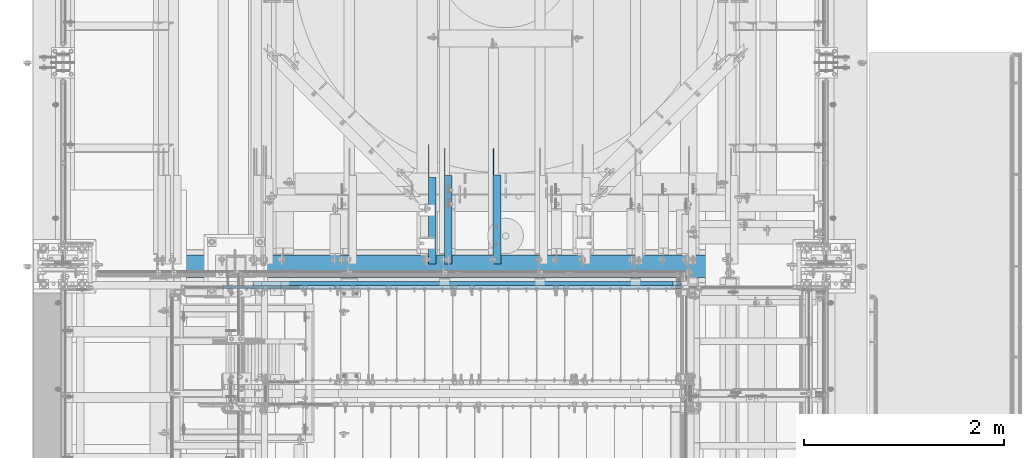
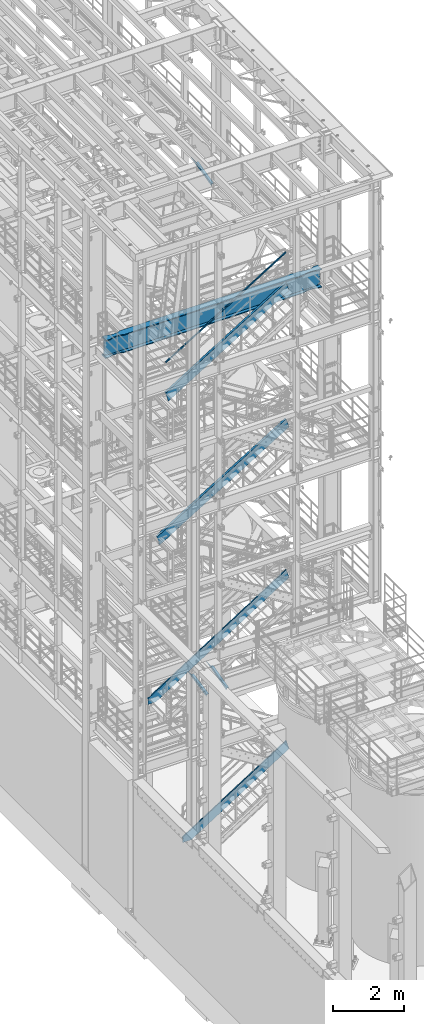
# One storey, part 979 of 1876: 5 members, 4 beams, 9 elements without a shape of their own.
"""IFC2X3 building model written with IfcOpenShell, lengths in millimetres."""

import ifcopenshell
import ifcopenshell.guid

model = None  # the IFC model being written
_history = None  # IfcOwnerHistory: only IFC2X3 demands one
_inside = {}  # id of a spatial element -> (the spatial element, [elements in it])
_under = {}  # id of a project, library or spatial element -> (it, [spatial elements below it])
_declared = {}  # id of a project -> (the project, [libraries it declares])
_typed = {}  # id of a type object -> (the type object, [elements of that type])
_made_of = {}  # id of a material, layer set ... -> (it, [elements and type objects made of it])


def new_model(schema):
    """Start an empty IFC model of exactly this schema.

    Asked for "IFC4X3", IfcOpenShell would pick the latest addendum, in which some entities
    have other attributes; the version numbers below select the first issue.
    IFC2X3 requires an IfcOwnerHistory on every rooted entity: one is made here for all.
    """
    global model, _history
    if schema == "IFC4X3":
        model = ifcopenshell.file(schema_version=(4, 3, 0, 0))
    else:
        model = ifcopenshell.file(schema=schema)
    _inside.clear()
    _under.clear()
    _declared.clear()
    _typed.clear()
    _made_of.clear()
    _history = None
    if model.schema == "IFC2X3":
        org = make("IfcOrganization", Name="unknown")
        user = make(
            "IfcPersonAndOrganization",
            ThePerson=make("IfcPerson", FamilyName="unknown"),
            TheOrganization=org,
        )
        app = make(
            "IfcApplication",
            ApplicationDeveloper=org,
            Version="unknown",
            ApplicationFullName="unknown",
            ApplicationIdentifier="unknown",
        )
        _history = make(
            "IfcOwnerHistory",
            OwningUser=user,
            OwningApplication=app,
            ChangeAction="ADDED",
            CreationDate=0,
        )
    return model


def make(cls, **values):
    """One entity of the class cls with the attributes given. An attribute that is None is left unset."""
    return model.create_entity(
        cls, **{name: value for name, value in values.items() if value is not None}
    )


def rooted(cls, **values):
    """An entity with a GlobalId (a new one), such as an element, a storey or a relation."""
    return make(cls, GlobalId=ifcopenshell.guid.new(), OwnerHistory=_history, **values)


def si_unit(unit_type, name, prefix=None):
    """IfcSIUnit, for example si_unit("LENGTHUNIT", "METRE", prefix="MILLI")."""
    return make("IfcSIUnit", UnitType=unit_type, Prefix=prefix, Name=name)


def assignment(units):
    """IfcUnitAssignment: the units of a project."""
    return None if units is None else make("IfcUnitAssignment", Units=units)


def point(xyz):
    """IfcCartesianPoint."""
    return None if xyz is None else make("IfcCartesianPoint", Coordinates=xyz)


def direction(xyz):
    """IfcDirection."""
    return None if xyz is None else make("IfcDirection", DirectionRatios=xyz)


def frame(location, z_axis=None, x_axis=None):
    """IfcAxis2Placement3D, a coordinate frame: its origin and axes. An axis left out is left unset."""
    return make(
        "IfcAxis2Placement3D",
        Location=point(location),
        Axis=direction(z_axis),
        RefDirection=direction(x_axis),
    )


def origin_with_axes():
    """The frame at (0, 0, 0) with the z axis (0, 0, 1) and the x axis (1, 0, 0) written out."""
    return frame((0.0, 0.0, 0.0), z_axis=(0.0, 0.0, 1.0), x_axis=(1.0, 0.0, 0.0))


def place(relative_to, where):
    """IfcLocalPlacement: puts the frame where relative to a parent placement (None: the world)."""
    return make(
        "IfcLocalPlacement", PlacementRelTo=relative_to, RelativePlacement=where
    )


def context(
    kind, dimensions, precision=None, world=None, true_north=None, identifier=None
):
    """IfcGeometricRepresentationContext, for example the 3D "Model" context."""
    return make(
        "IfcGeometricRepresentationContext",
        ContextIdentifier=identifier,
        ContextType=kind,
        CoordinateSpaceDimension=dimensions,
        Precision=precision,
        WorldCoordinateSystem=world,
        TrueNorth=true_north,
    )


def subcontext(parent, identifier, kind, view, scale=None):
    """IfcGeometricRepresentationSubContext, for example "Body" below "Model"."""
    return make(
        "IfcGeometricRepresentationSubContext",
        ContextIdentifier=identifier,
        ContextType=kind,
        ParentContext=parent,
        TargetScale=scale,
        TargetView=view,
    )


def project(units=None, contexts=None):
    """IfcProject with its units and contexts."""
    return rooted(
        "IfcProject",
        Name="project",
        RepresentationContexts=contexts,
        UnitsInContext=assignment(units),
    )


def spatial(cls, under=None, at=None, **own):
    """A site, building, storey or space (cls), placed at a placement, below another one or the project."""
    s = rooted(cls, ObjectPlacement=at, **own)
    if under is not None:
        _under.setdefault(under.id(), (under, []))[1].append(s)
    return s


def faces_of(points, faces, orient=None, outer=None):
    """IfcFace entities. A face is a list of loops; a loop is a list of indices into points, from 0.

    orient and outer hold one flag for each loop. By default every Orientation is true, the
    first loop of a face is its IfcFaceOuterBound and the others are IfcFaceBound.
    """
    made = []
    for i, loops in enumerate(faces):
        bounds = []
        for j, loop in enumerate(loops):
            is_outer = j == 0 if outer is None else outer[i][j]
            bounds.append(
                make(
                    "IfcFaceOuterBound" if is_outer else "IfcFaceBound",
                    Bound=make("IfcPolyLoop", Polygon=[points[k] for k in loop]),
                    Orientation=True if orient is None else orient[i][j],
                )
            )
        made.append(make("IfcFace", Bounds=bounds))
    return made


def faceted_brep(points, faces, orient=None, outer=None, voids=None):
    """IfcFacetedBrep: a solid bounded by flat faces; with voids (closed shells), ...WithVoids."""
    shared = [point(p) for p in points]
    hull = make("IfcClosedShell", CfsFaces=faces_of(shared, faces, orient, outer))
    if voids is None:
        return make("IfcFacetedBrep", Outer=hull)
    return make(
        "IfcFacetedBrepWithVoids",
        Outer=hull,
        Voids=[
            make(cls, CfsFaces=faces_of(shared, fs, o, b)) for cls, fs, o, b in voids
        ],
    )


def shape(context_of_items, identifier, shape_type, items):
    """IfcShapeRepresentation: the items that make up one representation, for example the "Body"."""
    return make(
        "IfcShapeRepresentation",
        ContextOfItems=context_of_items,
        RepresentationIdentifier=identifier,
        RepresentationType=shape_type,
        Items=items,
    )


def material(Name=None, Category=None):
    """IfcMaterial."""
    return make("IfcMaterial", Name=Name, Category=Category)


def made_of(thing, what):
    """Note that an element or type object is made of a material, layer set ...; save() writes the relation."""
    if what is not None:
        _made_of.setdefault(what.id(), (what, []))[1].append(thing)
    return thing


def type_object(cls, material=None, **own):
    """A type object (cls), such as IfcWallType, which elements share."""
    return made_of(rooted(cls, **own), material)


def element(
    cls,
    number,
    at=None,
    inside=None,
    cuts=None,
    type_object=None,
    material=None,
    context=None,
    identifier="Body",
    shape_type=None,
    held_by="IfcProductDefinitionShape",
    body=None,
    shapes=None,
    **own,
):
    """One element of the class cls, such as IfcWall. Its Tag is "e" and its number.

    at: its placement. inside: the storey or other place that contains it. cuts: it is an
    opening in that element (IfcRelVoidsElement). A single representation is given by context,
    identifier, shape_type and body (its items); several are given by shapes. held_by: the class
    of the entity that holds the representations. save() writes the other relations.
    """
    e = rooted(cls, Tag="e%d" % number, ObjectPlacement=at, **own)
    if body is not None:
        shapes = [shape(context, identifier, shape_type, body)]
    if shapes is not None:
        e.Representation = make(held_by, Representations=shapes)
    if inside is not None:
        _inside.setdefault(inside.id(), (inside, []))[1].append(e)
    if cuts is not None:
        rooted(
            "IfcRelVoidsElement", RelatingBuildingElement=cuts, RelatedOpeningElement=e
        )
    if type_object is not None:
        _typed.setdefault(type_object.id(), (type_object, []))[1].append(e)
    return made_of(e, material)


def aggregate(whole, parts):
    """IfcRelAggregates: a whole, such as a stair, and the parts it consists of."""
    return rooted("IfcRelAggregates", RelatingObject=whole, RelatedObjects=parts)


def save(model, path):
    """Write the relations noted so far, then the file.

    IfcRelAggregates (storeys below a building ...), IfcRelContainedInSpatialStructure (elements
    in a storey), IfcRelDefinesByType, IfcRelAssociatesMaterial and IfcRelDeclares: one each for
    every whole, place, type object, material and project.
    """
    for whole, parts in _under.values():
        aggregate(whole, parts)
    for where, things in _inside.values():
        rooted(
            "IfcRelContainedInSpatialStructure",
            RelatedElements=things,
            RelatingStructure=where,
        )
    for kind, things in _typed.values():
        rooted("IfcRelDefinesByType", RelatedObjects=things, RelatingType=kind)
    for what, things in _made_of.values():
        rooted("IfcRelAssociatesMaterial", RelatedObjects=things, RelatingMaterial=what)
    for by, libraries in _declared.values():
        rooted("IfcRelDeclares", RelatingContext=by, RelatedDefinitions=libraries)
    model.write(path)


model = new_model("IFC2X3")

# Units and contexts
model_context = context("Model", 3, precision=1e-05, world=origin_with_axes())
body_context = subcontext(model_context, "Body", "Model", "MODEL_VIEW")
ifc_project = project(units=[si_unit("LENGTHUNIT", "METRE", prefix="MILLI"), si_unit("AREAUNIT", "SQUARE_METRE"), si_unit("VOLUMEUNIT", "CUBIC_METRE"), si_unit("MASSUNIT", "GRAM", prefix="KILO"), si_unit("TIMEUNIT", "SECOND"), si_unit("PLANEANGLEUNIT", "RADIAN"), si_unit("SOLIDANGLEUNIT", "STERADIAN"), si_unit("THERMODYNAMICTEMPERATUREUNIT", "DEGREE_CELSIUS"), si_unit("LUMINOUSINTENSITYUNIT", "LUMEN")], contexts=[model_context])

# Site, building, storey
site_placement = place(None, origin_with_axes())
site = spatial("IfcSite", under=ifc_project, at=site_placement, CompositionType="ELEMENT")
building_placement = place(site_placement, origin_with_axes())
building = spatial("IfcBuilding", under=site, at=building_placement, Name="Undefined", CompositionType="ELEMENT")
storey_placement = place(building_placement, origin_with_axes())
storey = spatial("IfcBuildingStorey", under=building, at=storey_placement, Name="Undefined", CompositionType="ELEMENT", Elevation=0.0)

# Assembly, beam
assembly_1_placement = place(storey_placement, origin_with_axes())
assembly_1 = element("IfcElementAssembly", 1, at=assembly_1_placement, inside=storey, AssemblyPlace="NOTDEFINED", PredefinedType="RIGID_FRAME")
ifc_material_1 = material(Name="STEEL/A36")
beam_type_1 = type_object("IfcBeamType", Name="L3X3X3/8", PredefinedType="NOTDEFINED")
beam_1_placement = place(assembly_1_placement, frame((4333.87499990463, -4562.3143433578, 4558.96418871958), z_axis=(1.0, 0.0, 0.0), x_axis=(0.0, 0.967147277703795, 0.254216724922138)))
beam_1 = element("IfcBeam", 2, at=beam_1_placement, type_object=beam_type_1, material=ifc_material_1, ObjectType="L3X3X3/8", context=body_context, shape_type="Brep", body=[
    faceted_brep([(23.7928828385348, 38.099999999994, -38.1000000000004), (23.7928828385348, 38.099999999994, 38.1000000000004), (905.477403464634, 38.1000000000176, 38.1000000000004), (905.477403464634, 38.1000000000176, -38.1000000000004), (23.7809703256453, 28.5749999999953, 38.1000000000004), (941.714507152235, 28.5750000000207, 38.1000000000004), (23.7809703256453, 28.5749999999953, -28.5749999999998), (941.714507152235, 28.5750000000207, -28.5749999999998), (23.6975827354227, -38.0999999999913, -28.5749999999998), (1195.37423296544, -38.0999999999585, -28.5749999999998), (23.6975827354227, -38.0999999999913, -38.1000000000004), (1195.37423296544, -38.0999999999585, -38.1000000000004)], [[[0, 1, 2, 3]], [[1, 4, 5, 2]], [[4, 6, 7, 5]], [[6, 8, 9, 7]], [[8, 10, 11, 9]], [[10, 0, 3, 11]], [[5, 7, 9, 11, 3, 2]], [[10, 8, 6, 4, 1, 0]]]),
])
aggregate(assembly_1, [beam_1])

assembly_2_placement = place(storey_placement, origin_with_axes())
assembly_2 = element("IfcElementAssembly", 3, at=assembly_2_placement, inside=storey, AssemblyPlace="NOTDEFINED", PredefinedType="RIGID_FRAME")
beam_2_placement = place(assembly_2_placement, frame((3844.92500019074, -4562.78281844778, 21997.5317219592), z_axis=(1.0, 0.0, 0.0), x_axis=(0.0, 0.97029600569138, 0.241920774923019)))
beam_2 = element("IfcBeam", 4, at=beam_2_placement, type_object=beam_type_1, material=ifc_material_1, ObjectType="L3X3X3/8", context=body_context, shape_type="Brep", body=[
    faceted_brep([(20.4512332895073, 38.1000000000495, -38.0999999999999), (20.4512332895073, 38.1000000000495, 38.0999999999999), (892.440924395522, 38.0999999997366, 38.0999999999999), (892.440924395522, 38.0999999997366, -38.0999999999999), (20.4512332895037, 28.5750000000371, 38.0999999999999), (930.643800759319, 28.5749999997061, 38.0999999999999), (20.4512332895037, 28.5750000000371, -28.575), (930.643800759319, 28.5749999997061, -28.575), (20.4512332894728, -38.1000000000604, -28.575), (1198.0639353059, -38.1000000004824, -28.575), (20.4512332894728, -38.1000000000604, -38.0999999999999), (1198.0639353059, -38.1000000004824, -38.0999999999999)], [[[0, 1, 2, 3]], [[1, 4, 5, 2]], [[4, 6, 7, 5]], [[6, 8, 9, 7]], [[8, 10, 11, 9]], [[10, 0, 3, 11]], [[5, 7, 9, 11, 3, 2]], [[10, 8, 6, 4, 1, 0]]]),
])
aggregate(assembly_2, [beam_2])

assembly_3_placement = place(storey_placement, origin_with_axes())
assembly_3 = element("IfcElementAssembly", 5, at=assembly_3_placement, inside=storey, AssemblyPlace="NOTDEFINED", PredefinedType="RIGID_FRAME")
beam_3_placement = place(assembly_3_placement, frame((3685.38125, -4564.3470414959, 4572.77651984672), z_axis=(1.0, 0.0, 0.0), x_axis=(0.0, 0.979618903835332, 0.200865136966229)))
beam_3 = element("IfcBeam", 6, at=beam_3_placement, type_object=beam_type_1, material=ifc_material_1, ObjectType="L3X3X3/8", context=body_context, shape_type="Brep", body=[
    faceted_brep([(23.4976613090944, 38.0999999999913, -38.0999999999999), (23.4976613090944, 38.0999999999913, 38.0999999999999), (853.557777655543, 38.0999999998658, 38.0999999999999), (853.557777655543, 38.0999999998658, -38.0999999999999), (23.4976613090939, 28.5749999999935, 38.0999999999999), (900.01118515057, 28.5749999998607, 38.0999999999999), (23.4976613090939, 28.5749999999935, -28.5749999999998), (900.01118515057, 28.5749999998607, -28.5749999999998), (23.4976613090939, -38.0999999999976, -28.5749999999998), (1225.18503761576, -38.1000000001786, -28.5749999999998), (23.4976613090939, -38.0999999999976, -38.0999999999999), (1225.18503761576, -38.1000000001786, -38.0999999999999)], [[[0, 1, 2, 3]], [[1, 4, 5, 2]], [[4, 6, 7, 5]], [[6, 8, 9, 7]], [[8, 10, 11, 9]], [[10, 0, 3, 11]], [[5, 7, 9, 11, 3, 2]], [[10, 8, 6, 4, 1, 0]]]),
])
aggregate(assembly_3, [beam_3])

# Assembly, member
assembly_4_placement = place(storey_placement, origin_with_axes())
assembly_4 = element("IfcElementAssembly", 7, at=assembly_4_placement, inside=storey, Name="RAIL", AssemblyPlace="NOTDEFINED", PredefinedType="RIGID_FRAME")
ifc_material_2 = material()
member_type_1 = type_object("IfcMemberType", Name="HSS1-1/2X1-1/2X1/8", PredefinedType="NOTDEFINED")
member_1_placement = place(assembly_4_placement, frame((6080.62411478707, -4781.55000114554, 19050.0), z_axis=(0.526627379729771, 0.0, -0.850096231563789), x_axis=(-0.850096231563789, 0.0, -0.526627379729771)))
member_1 = element("IfcMember", 8, at=member_1_placement, type_object=member_type_1, material=ifc_material_2, Name="RAIL", ObjectType="HSS1-1/2X1-1/2X1/8", context=body_context, shape_type="Brep", body=[
    faceted_brep([(-4.5187969689996, 15.8749992829999, -15.8749992829871), (-4.5187969689996, -15.8749992829999, -15.8749992829871), (4579.03162456834, -15.8749992829999, -15.8749992763478), (4579.03162456834, 15.8749992829999, -15.8749992763478), (4.51879699284473, -15.8749992829999, 15.8749992829871), (4588.06921853025, -15.8749992829999, 15.8749992896428), (4.51879699284473, 15.8749992829999, 15.8749992829871), (4588.06921853025, 15.8749992829999, 15.8749992896428), (-5.42255639234099, 19.0499992349996, -19.0499992349833), (5.42255641618613, 19.0499992349996, 19.0499992349851), (4588.97297795359, 19.0499992349996, 19.0499992416389), (4578.12786514499, 19.0499992349996, -19.0499992283476), (5.42255641618613, -19.0499992349996, 19.0499992349851), (4588.97297795359, -19.0499992349996, 19.0499992416389), (-5.42255639234099, -19.0499992349996, -19.0499992349833), (4578.12786514499, -19.0499992349996, -19.0499992283476)], [[[0, 1, 2, 3]], [[1, 4, 5, 2]], [[4, 6, 7, 5]], [[6, 0, 3, 7]], [[8, 9, 10, 11]], [[9, 12, 13, 10]], [[12, 14, 15, 13]], [[14, 8, 11, 15]], [[13, 15, 11, 10], [5, 7, 3, 2]], [[14, 12, 9, 8], [6, 4, 1, 0]]]),
])
aggregate(assembly_4, [member_1])

assembly_5_placement = place(storey_placement, origin_with_axes())
assembly_5 = element("IfcElementAssembly", 9, at=assembly_5_placement, inside=storey, Name="STRINGER", AssemblyPlace="NOTDEFINED", PredefinedType="RIGID_FRAME")
member_type_2 = type_object("IfcMemberType", Name="C12X20.7", PredefinedType="NOTDEFINED")
member_2_placement = place(assembly_5_placement, frame((6169.03104247719, -4762.50000114494, 17888.572489046), z_axis=(-0.526650190166568, 0.0, 0.850082100268861), x_axis=(-0.850082100268861, 0.0, -0.526650190166567)))
member_2 = element("IfcMember", 10, at=member_2_placement, type_object=member_type_2, material=ifc_material_1, Name="STRINGER", ObjectType="C12X20.7", context=body_context, shape_type="Brep", body=[
    faceted_brep([(86.7653265610461, 38.1000000000004, -152.399999999901), (0.0, 38.1000000000004, 152.4), (4601.43790875364, 38.1000000000004, 152.399999995085), (4688.20323538842, 38.1000000000004, -152.400000004627), (0.0, -38.1000000000004, 152.4), (4601.43790875364, -38.1000000000004, 152.399999995085), (1.80833394220826, -38.1000000000004, 146.04745999982), (4603.24624276958, -38.1000000000004, 146.04745999509), (5.04567481172126, 30.1625000000004, 134.674927499829), (4606.4835836391, 30.1625000000004, 134.674927495102), (81.7196516755866, 30.1625000000004, -134.674927499917), (4683.15756050296, 30.1625000000004, -134.674927504644), (84.9569925450996, -38.1000000000004, -146.047459999907), (4686.39490137247, -38.1000000000004, -146.047460004633), (86.7653265610461, -38.1000000000004, -152.399999999901), (4688.20323538842, -38.1000000000004, -152.400000004627)], [[[0, 1, 2, 3]], [[1, 4, 5, 2]], [[4, 6, 7, 5]], [[6, 8, 9, 7]], [[8, 10, 11, 9]], [[10, 12, 13, 11]], [[12, 14, 15, 13]], [[14, 0, 3, 15]], [[5, 7, 9, 11, 13, 15, 3, 2]], [[14, 12, 10, 8, 6, 4, 1, 0]]]),
])
aggregate(assembly_5, [member_2])

assembly_6_placement = place(storey_placement, origin_with_axes())
assembly_6 = element("IfcElementAssembly", 11, at=assembly_6_placement, inside=storey, Name="STRINGER", AssemblyPlace="NOTDEFINED", PredefinedType="RIGID_FRAME")
member_3_placement = place(assembly_6_placement, frame((6168.66354763905, -4762.50000114942, 13214.7187687466), z_axis=(-0.523953411146183, 0.0, 0.851746924237639), x_axis=(-0.851746924237639, 0.0, -0.523953411146184)))
member_3 = element("IfcMember", 12, at=member_3_placement, type_object=member_type_2, material=ifc_material_1, Name="STRINGER", ObjectType="C12X20.7", context=body_context, shape_type="Brep", body=[
    faceted_brep([(86.2434264438216, 38.1000000000004, -152.400000000001), (0.0, 38.1000000000004, 152.4), (4920.47564755946, 38.1000000000004, 152.400000001153), (5006.71907404049, 38.1000000000004, -152.399999998875), (0.0, -38.1000000000004, 152.4), (4920.47564755946, -38.1000000000004, 152.400000001153), (1.79745670970442, -38.1000000000004, 146.047460000024), (4922.27310430637, -38.1000000000004, 146.047460001151), (5.01532472337567, 30.1625000000004, 134.674927500021), (4925.49097232005, 30.1625000000004, 134.674927501152), (81.2281016832421, 30.1625000000004, -134.674927499999), (5001.70374927992, 30.1625000000004, -134.674927498872), (84.4459696969134, -38.1000000000004, -146.047460000002), (5004.92161729358, -38.1000000000004, -146.047459998875), (86.2434264438216, -38.1000000000004, -152.400000000001), (5006.71907404049, -38.1000000000004, -152.399999998875)], [[[0, 1, 2, 3]], [[1, 4, 5, 2]], [[4, 6, 7, 5]], [[6, 8, 9, 7]], [[8, 10, 11, 9]], [[10, 12, 13, 11]], [[12, 14, 15, 13]], [[14, 0, 3, 15]], [[5, 7, 9, 11, 13, 15, 3, 2]], [[14, 12, 10, 8, 6, 4, 1, 0]]]),
])
aggregate(assembly_6, [member_3])

assembly_7_placement = place(storey_placement, origin_with_axes())
assembly_7 = element("IfcElementAssembly", 13, at=assembly_7_placement, inside=storey, Name="STRINGER", AssemblyPlace="NOTDEFINED", PredefinedType="RIGID_FRAME")
member_type_3 = type_object("IfcMemberType", Name="MC12X10.6", PredefinedType="NOTDEFINED")
member_4_placement = place(assembly_7_placement, frame((6170.42332168081, -4781.55000113033, 8059.75098794068), z_axis=(-0.536875491934336, 0.0, 0.843661487896813), x_axis=(-0.843661487896813, 0.0, -0.536875491934336)))
member_4 = element("IfcMember", 14, at=member_4_placement, type_object=member_type_3, material=ifc_material_1, Name="STRINGER", ObjectType="MC12X10.6", context=body_context, shape_type="Brep", body=[
    faceted_brep([(88.7579695903842, -19.0500000000002, -152.399999999925), (86.5569568567735, -19.0500000000002, -144.841594999928), (86.3637695885682, 14.2875000000004, -144.178178749929), (2.39419999348684, 14.2875000000004, 144.178178749939), (2.20101272528336, -19.0500000000002, 144.841594999938), (-1.68647966347635e-06, -19.0500000000002, 152.400000000001), (-1.68647966347635e-06, 19.0500000000002, 152.400000000001), (88.7579695903842, 19.0500000000002, -152.399999999925), (5204.2363930058, 19.0500000000002, -152.39999999936), (5204.2363930058, -19.0500000000002, -152.39999999936), (5216.11388656315, -19.0500000000002, -144.841594999362), (5217.15639781191, 14.2875000000004, -144.178178749362), (5424.79425146145, 14.2875000000004, -12.0449989975828), (5325.37950186754, 14.2875000000004, 144.178178750526), (5324.95732788977, -19.0500000000002, 144.841595000525), (5320.14743379316, -19.0500000000002, 152.400000000522), (5320.14743379316, 19.0500000000002, 152.400000000522), (5424.79425146145, 19.0500000000002, -12.0449989975828)], [[[0, 1, 2, 3, 4, 5, 6, 7]], [[0, 7, 8, 9]], [[1, 0, 9, 10]], [[2, 1, 10, 11]], [[3, 2, 11, 12, 13]], [[4, 3, 13, 14]], [[5, 4, 14, 15]], [[6, 5, 15, 16]], [[8, 7, 6, 16, 17]], [[11, 10, 9, 8, 17, 12]], [[16, 15, 14, 13, 12, 17]]]),
])
aggregate(assembly_7, [member_4])

assembly_8_placement = place(storey_placement, origin_with_axes())
assembly_8 = element("IfcElementAssembly", 15, at=assembly_8_placement, inside=storey, Name="STRINGER", AssemblyPlace="NOTDEFINED", PredefinedType="RIGID_FRAME")
member_5_placement = place(assembly_8_placement, frame((6170.26301538892, -4781.55000120553, 2200.99553374349), z_axis=(-0.53569741975471, 0.0, 0.844410015613355), x_axis=(-0.844410015613354, 0.0, -0.53569741975471)))
member_5 = element("IfcMember", 16, at=member_5_placement, type_object=member_type_3, material=ifc_material_1, Name="STRINGER", ObjectType="MC12X10.6", context=body_context, shape_type="Brep", body=[
    faceted_brep([(88.527264823621, -19.0500000000002, -152.4), (86.3319730877715, -19.0500000000002, -144.841595), (86.1392879629268, 14.2875000000004, -144.17817875), (2.38797685967643, 14.2875000000004, 144.17817875), (2.19529173483147, -19.0500000000002, 144.841595), (-1.68647966347635e-06, -19.0500000000002, 152.400000000001), (-1.68647966347635e-06, 19.0500000000002, 152.400000000001), (88.527264823621, 19.0500000000002, -152.4), (3844.87479961239, 19.0500000000002, -152.400000001044), (3844.87479961239, -19.0500000000002, -152.400000001044), (3856.78897475809, -19.0500000000002, -144.841595001047), (3857.83470562287, 14.2875000000004, -144.178178751047), (4087.60257997168, 14.2875000000004, 1.5875691147512), (3997.14247143452, 14.2875000000004, 144.178178748953), (3996.72159725399, -19.0500000000002, 144.841594998953), (3991.92651195054, -19.0500000000002, 152.399999998955), (3991.92651195054, 19.0500000000002, 152.399999998955), (4087.60257997168, 19.0500000000002, 1.5875691147512)], [[[0, 1, 2, 3, 4, 5, 6, 7]], [[0, 7, 8, 9]], [[1, 0, 9, 10]], [[2, 1, 10, 11]], [[3, 2, 11, 12, 13]], [[4, 3, 13, 14]], [[5, 4, 14, 15]], [[6, 5, 15, 16]], [[8, 7, 6, 16, 17]], [[11, 10, 9, 8, 17, 12]], [[16, 15, 14, 13, 12, 17]]]),
])
aggregate(assembly_8, [member_5])

# Assembly, beam
assembly_9_placement = place(storey_placement, origin_with_axes())
assembly_9 = element("IfcElementAssembly", 17, at=assembly_9_placement, inside=storey, Name="BEAM", AssemblyPlace="NOTDEFINED", PredefinedType="RIGID_FRAME")
ifc_material_3 = material(Name="STEEL/A992")
beam_type_2 = type_object("IfcBeamType", Name="W24X103", PredefinedType="NOTDEFINED")
beam_4_placement = place(assembly_9_placement, frame((0.0, -4572.0, 17672.05), z_axis=(0.0, 0.0, 1.0), x_axis=(1.0, 0.0, 0.0)))
beam_4 = element("IfcBeam", 18, at=beam_4_placement, type_object=beam_type_2, material=ifc_material_3, Name="BEAM", ObjectType="W24X103", context=body_context, shape_type="Brep", body=[
    faceted_brep([(301.625, 7.14375000000018, -250.825000000001), (309.5625, -7.14375000000018, -250.825000000001), (309.5625, -7.14375000000018, 250.825000000001), (301.625, 7.14375000000018, 250.825000000001), (7318.375, 7.14375000000018, 250.825000000001), (7310.4375, -7.14375000000018, 250.825000000001), (7310.4375, -7.14375000000018, -250.825000000001), (7318.375, 7.14375000000018, -250.825000000001), (7162.79999999982, 114.299999516767, -285.75), (7162.79999999982, 114.3, -311.150000000001), (7113.70085269938, 88.9000029223316, -311.150000000001), (7113.70085269938, 88.9000029223316, -285.75), (7031.26184334843, 69.8863995920019, -311.150000000001), (7031.26184334843, 69.8863995920019, -285.75), (6946.89999522536, 63.5000112833413, -311.150000000001), (6946.89999522536, 63.5000112833413, -285.75), (6862.53814723751, 69.8864013782631, -311.150000000001), (6862.53814723751, 69.8864013782631, -285.75), (6780.09913828916, 88.9000064541397, -311.150000000001), (6780.09913828916, 88.9000064541397, -285.75), (6730.99999123786, 114.3, -311.150000000001), (6730.99999123786, 114.3, -285.75), (889.000008761879, 114.3, -311.150000000001), (889.000008761879, 114.299990374482, -285.75), (839.9008617106, 88.8999896424721, -311.150000000001), (839.9008617106, 88.8999896424721, -285.75), (757.461852762268, 69.8863845665956, -311.150000000001), (757.461852762268, 69.8863845665956, -285.75), (673.100004774441, 63.4999944716737, -311.150000000001), (673.100004774441, 63.4999944716737, -285.75), (588.738156651386, 69.8863827803343, -311.150000000001), (588.738156651386, 69.8863827803343, -285.75), (506.299147300449, 88.899986110664, -311.150000000001), (506.299147300449, 88.899986110664, -285.75), (457.200000000009, 114.3, -311.150000000001), (457.200000000009, 114.3, -285.75), (301.625, 114.3, -311.150000000001), (316.28959905754, 114.3, -285.75), (7162.79999999982, -114.299985144468, -285.75), (7113.70085269938, -88.8999885500325, -285.75), (7113.70085269938, -88.8999885500325, -311.150000000001), (7162.79999999982, -114.3, -311.150000000001), (7031.26184334843, -69.8863852197028, -285.75), (7031.26184334843, -69.8863852197028, -311.150000000001), (6946.89999522536, -63.4999969110422, -285.75), (6946.89999522536, -63.4999969110422, -311.150000000001), (6862.53814723751, -69.886387005964, -285.75), (6862.53814723751, -69.886387005964, -311.150000000001), (6780.09913828916, -88.8999920818405, -285.75), (6780.09913828916, -88.8999920818405, -311.150000000001), (6730.99999123786, -114.3, -285.75), (6730.99999123786, -114.3, -311.150000000001), (889.000008761879, -114.300009625518, -285.75), (889.000008761879, -114.3, -311.150000000001), (839.9008617106, -88.9000088935081, -285.75), (839.9008617106, -88.9000088935081, -311.150000000001), (757.461852762268, -69.8864038176316, -285.75), (757.461852762268, -69.8864038176316, -311.150000000001), (673.100004774441, -63.5000137227098, -285.75), (673.100004774441, -63.5000137227098, -311.150000000001), (588.738156651386, -69.8864020313704, -285.75), (588.738156651386, -69.8864020313704, -311.150000000001), (506.299147300449, -88.9000053617001, -285.75), (506.299147300449, -88.9000053617001, -311.150000000001), (457.200000000009, -114.3, -285.75), (457.200000000009, -114.3, -311.150000000001), (316.28959905754, -114.3, -285.75), (301.625, -114.3, -311.150000000001), (316.518799385621, -7.14375000000018, -285.35299987793), (316.518799385621, 7.14375000000018, -285.35299987793), (316.28959905754, 7.14375000000018, -285.75), (316.28959905754, -7.14375000000018, -285.75), (350.084996826172, -7.14375000000018, -285.35299987793), (350.084996826172, 7.14375000000018, -285.35299987793), (385.557251149282, -7.14375000000018, -269.000062630286), (385.557251149282, 7.14375000000018, -269.000062630286), (389.447459055476, -7.14375000000018, -265.703842989446), (389.447459055476, 7.14375000000018, -265.703842989446), (391.080124802588, -7.14375000000018, -260.873399528195), (391.080124802588, 7.14375000000018, -260.873399528195), (389.98738362386, -7.14375000000018, -255.89296800167), (389.98738362386, 7.14375000000018, -255.89296800167), (386.482376832887, -7.14375000000018, -252.189765486371), (386.482376832887, 7.14375000000018, -252.189765486371), (381.56951650093, -7.14375000000018, -250.825000000001), (381.56951650093, 7.14375000000018, -250.825000000001), (380.734514535493, -7.14375000000018, 250.825000000001), (380.734514535493, 7.14375000000018, 250.825000000001), (385.647374804242, -7.14375000000018, 252.189765448315), (385.647374804242, 7.14375000000018, 252.189765448315), (389.152381589376, -7.14375000000018, 255.892967871263), (389.152381589376, 7.14375000000018, 255.892967871263), (390.245122849314, -7.14375000000018, 260.873399307191), (390.245122849314, 7.14375000000018, 260.873399307191), (388.612457255921, -7.14375000000018, 265.703842745359), (388.612457255921, 7.14375000000018, 265.703842745359), (384.722249518856, -7.14375000000018, 269.000062475843), (384.722249518856, 7.14375000000018, 269.000062475843), (349.249998474121, -7.14375000000018, 285.35299987793), (349.249998474121, 7.14375000000018, 285.35299987793), (301.625, -7.14375000000018, 285.35299987793), (301.625, 7.14375000000018, 285.35299987793), (457.200000000009, 114.3, 311.150000000001), (457.200000000009, 114.3, 285.75), (301.625, 114.3, 285.75), (316.289586308271, 114.3, 311.150000000001), (506.299147300449, 88.899986110664, 311.150000000001), (506.299147300449, 88.899986110664, 285.75), (588.738156651386, 69.8863827803343, 311.150000000001), (588.738156651386, 69.8863827803343, 285.75), (673.100004774441, 63.4999944716737, 311.150000000001), (673.100004774441, 63.4999944716737, 285.75), (757.461852762268, 69.8863845665956, 311.150000000001), (757.461852762268, 69.8863845665956, 285.75), (839.9008617106, 88.8999896424721, 311.150000000001), (839.9008617106, 88.8999896424721, 285.75), (889.000008761879, 114.299990374482, 311.150000000001), (889.000008761879, 114.3, 285.75), (6730.99999123786, 114.3, 311.150000000001), (6730.99999123786, 114.3, 285.75), (6780.09913828916, 88.9000064541397, 311.150000000001), (6780.09913828916, 88.9000064541397, 285.75), (6862.53814723751, 69.8864013782631, 311.150000000001), (6862.53814723751, 69.8864013782631, 285.75), (6946.89999522536, 63.5000112833413, 311.150000000001), (6946.89999522536, 63.5000112833413, 285.75), (7031.26184334843, 69.8863995920019, 311.150000000001), (7031.26184334843, 69.8863995920019, 285.75), (7113.70085269938, 88.9000029223316, 311.150000000001), (7113.70085269938, 88.9000029223316, 285.75), (7162.79999999982, 114.299999516767, 311.150000000001), (7162.79999999982, 114.3, 285.75), (7303.71041369173, 114.29999995445, 311.150000000001), (7318.375, 114.3, 285.75), (301.625, 7.14375000000018, 285.75), (7318.375, 7.14375000000018, 285.75), (7318.375, -7.14375000000018, 285.35299987793), (7318.375, 7.14375000000018, 285.35299987793), (7318.375, -7.14375000000018, 285.75), (7270.75000152588, -7.14375000000018, 285.35299987793), (7270.75000152588, 7.14375000000018, 285.35299987793), (7235.27775048114, -7.14375000000018, 269.000062475843), (7235.27775048114, 7.14375000000018, 269.000062475843), (7231.38754274408, -7.14375000000018, 265.703842745359), (7231.38754274408, 7.14375000000018, 265.703842745359), (7229.75487715069, -7.14375000000018, 260.873399307191), (7229.75487715069, 7.14375000000018, 260.873399307191), (7230.84761841062, -7.14375000000018, 255.892967871263), (7230.84761841062, 7.14375000000018, 255.892967871263), (7234.35262519576, -7.14375000000018, 252.189765448315), (7234.35262519576, 7.14375000000018, 252.189765448315), (7239.26548546451, -7.14375000000018, 250.825000000001), (7239.26548546451, 7.14375000000018, 250.825000000001), (7238.43048349907, -7.14375000000018, -250.825000000001), (7238.43048349907, 7.14375000000018, -250.825000000001), (7233.51762316711, -7.14375000000018, -252.189765486371), (7233.51762316711, 7.14375000000018, -252.189765486371), (7230.01261637614, -7.14375000000018, -255.89296800167), (7230.01261637614, 7.14375000000018, -255.89296800167), (7228.91987519741, -7.14375000000018, -260.873399528195), (7228.91987519741, 7.14375000000018, -260.873399528195), (7230.55254094452, -7.14375000000018, -265.703842989446), (7230.55254094452, 7.14375000000018, -265.703842989446), (7234.44274885072, -7.14375000000018, -269.000062630286), (7234.44274885072, 7.14375000000018, -269.000062630286), (7269.91500317383, -7.14375000000018, -285.35299987793), (7269.91500317383, 7.14375000000018, -285.35299987793), (7303.48120061438, -7.14375000000018, -285.35299987793), (7303.48120061438, 7.14375000000018, -285.35299987793), (7303.71040094246, 7.14375000000018, -285.75), (7303.71040094246, 114.29999995445, -285.75), (7318.375, 114.3, -311.150000000001), (7318.375, -114.3, -311.150000000001), (7303.71040094246, -114.299998599708, -285.75), (7303.71040094246, -7.14375000000018, -285.75), (301.625, -7.14375000000018, 285.75), (316.289586308271, -114.3, 311.150000000001), (301.625, -114.3, 285.75), (457.200000000009, -114.3, 285.75), (457.200000000009, -114.3, 311.150000000001), (506.299147300449, -88.9000053617001, 285.75), (506.299147300449, -88.9000053617001, 311.150000000001), (588.738156651386, -69.8864020313704, 285.75), (588.738156651386, -69.8864020313704, 311.150000000001), (673.100004774441, -63.5000137227098, 285.75), (673.100004774441, -63.5000137227098, 311.150000000001), (757.461852762268, -69.8864038176316, 285.75), (757.461852762268, -69.8864038176316, 311.150000000001), (839.9008617106, -88.9000088935081, 285.75), (839.9008617106, -88.9000088935081, 311.150000000001), (889.000008761879, -114.300009625518, 311.150000000001), (889.000008761879, -114.3, 285.75), (6730.99999123786, -114.3, 285.75), (6730.99999123786, -114.3, 311.150000000001), (6780.09913828916, -88.8999920818405, 285.75), (6780.09913828916, -88.8999920818405, 311.150000000001), (6862.53814723751, -69.886387005964, 285.75), (6862.53814723751, -69.886387005964, 311.150000000001), (6946.89999522536, -63.4999969110422, 285.75), (6946.89999522536, -63.4999969110422, 311.150000000001), (7031.26184334843, -69.8863852197028, 285.75), (7031.26184334843, -69.8863852197028, 311.150000000001), (7113.70085269938, -88.8999885500325, 285.75), (7113.70085269938, -88.8999885500325, 311.150000000001), (7162.79999999982, -114.299985144468, 311.150000000001), (7162.79999999982, -114.3, 285.75), (7318.375, -114.3, 285.75), (7303.71041369173, -114.299998599709, 311.150000000001)], [[[0, 1, 2, 3]], [[4, 5, 6, 7]], [[8, 9, 10, 11]], [[11, 10, 12, 13]], [[13, 12, 14, 15]], [[15, 14, 16, 17]], [[17, 16, 18, 19]], [[19, 18, 20, 21]], [[21, 20, 22, 23]], [[23, 22, 24, 25]], [[25, 24, 26, 27]], [[27, 26, 28, 29]], [[29, 28, 30, 31]], [[31, 30, 32, 33]], [[33, 32, 34, 35]], [[35, 34, 36, 37]], [[38, 39, 40, 41]], [[42, 43, 40, 39]], [[44, 45, 43, 42]], [[46, 47, 45, 44]], [[48, 49, 47, 46]], [[50, 51, 49, 48]], [[51, 50, 52, 53]], [[52, 54, 55, 53]], [[56, 57, 55, 54]], [[58, 59, 57, 56]], [[60, 61, 59, 58]], [[62, 63, 61, 60]], [[64, 65, 63, 62]], [[65, 64, 66, 67]], [[68, 69, 70, 37, 36, 67, 66, 71]], [[72, 73, 69, 68]], [[74, 75, 73, 72]], [[76, 77, 75, 74]], [[78, 79, 77, 76]], [[80, 81, 79, 78]], [[82, 83, 81, 80]], [[84, 85, 83, 82]], [[85, 84, 1, 0]], [[86, 87, 3, 2]], [[88, 89, 87, 86]], [[90, 91, 89, 88]], [[92, 93, 91, 90]], [[94, 95, 93, 92]], [[96, 97, 95, 94]], [[98, 99, 97, 96]], [[99, 98, 100, 101]], [[102, 103, 104, 105]], [[106, 107, 103, 102]], [[108, 109, 107, 106]], [[110, 111, 109, 108]], [[112, 113, 111, 110]], [[114, 115, 113, 112]], [[116, 117, 115, 114]], [[118, 119, 117, 116]], [[120, 121, 119, 118]], [[122, 123, 121, 120]], [[124, 125, 123, 122]], [[126, 127, 125, 124]], [[128, 129, 127, 126]], [[130, 131, 129, 128]], [[131, 130, 132, 133]], [[134, 104, 103, 107, 109, 111, 113, 115, 117, 119, 121, 123, 125, 127, 129, 131, 133, 135]], [[136, 137, 135, 138]], [[139, 140, 137, 136]], [[141, 142, 140, 139]], [[143, 144, 142, 141]], [[145, 146, 144, 143]], [[147, 148, 146, 145]], [[149, 150, 148, 147]], [[151, 152, 150, 149]], [[152, 151, 5, 4]], [[153, 154, 7, 6]], [[155, 156, 154, 153]], [[157, 158, 156, 155]], [[159, 160, 158, 157]], [[161, 162, 160, 159]], [[163, 164, 162, 161]], [[165, 166, 164, 163]], [[166, 165, 167, 168]], [[70, 69, 73, 75, 77, 79, 81, 83, 85, 0, 3, 87, 89, 91, 93, 95, 97, 99, 101, 134, 135, 137, 140, 142, 144, 146, 148, 150, 152, 4, 7, 154, 156, 158, 160, 162, 164, 166, 168, 169]], [[8, 11, 13, 15, 17, 19, 21, 23, 25, 27, 29, 31, 33, 35, 37, 70, 169, 170]], [[9, 8, 170, 171]], [[41, 40, 43, 45, 47, 49, 51, 53, 55, 57, 59, 61, 63, 65, 67, 36, 34, 32, 30, 28, 26, 24, 22, 20, 18, 16, 14, 12, 10, 9, 171, 172]], [[38, 41, 172, 173]], [[71, 66, 64, 62, 60, 58, 56, 54, 52, 50, 48, 46, 44, 42, 39, 38, 173, 174]], [[172, 171, 170, 169, 168, 167, 174, 173]], [[84, 82, 80, 78, 76, 74, 72, 68, 71, 174, 167, 165, 163, 161, 159, 157, 155, 153, 6, 5, 151, 149, 147, 145, 143, 141, 139, 136, 138, 175, 100, 98, 96, 94, 92, 90, 88, 86, 2, 1]], [[101, 100, 175, 134]], [[176, 105, 104, 134, 175, 177]], [[178, 179, 176, 177]], [[179, 178, 180, 181]], [[181, 180, 182, 183]], [[183, 182, 184, 185]], [[185, 184, 186, 187]], [[187, 186, 188, 189]], [[190, 189, 188, 191]], [[192, 193, 190, 191]], [[193, 192, 194, 195]], [[195, 194, 196, 197]], [[197, 196, 198, 199]], [[199, 198, 200, 201]], [[201, 200, 202, 203]], [[204, 205, 206, 207]], [[130, 128, 126, 124, 122, 120, 118, 116, 114, 112, 110, 108, 106, 102, 105, 176, 179, 181, 183, 185, 187, 189, 190, 193, 195, 197, 199, 201, 203, 204, 207, 132]], [[206, 138, 135, 133, 132, 207]], [[205, 202, 200, 198, 196, 194, 192, 191, 188, 186, 184, 182, 180, 178, 177, 175, 138, 206]], [[204, 203, 202, 205]]]),
])
aggregate(assembly_9, [beam_4])

save(model, "model.ifc")
